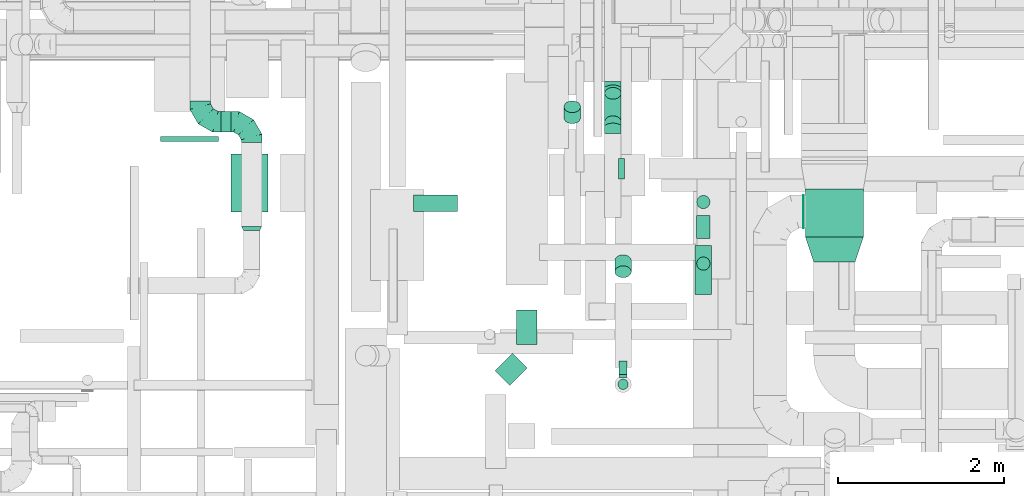
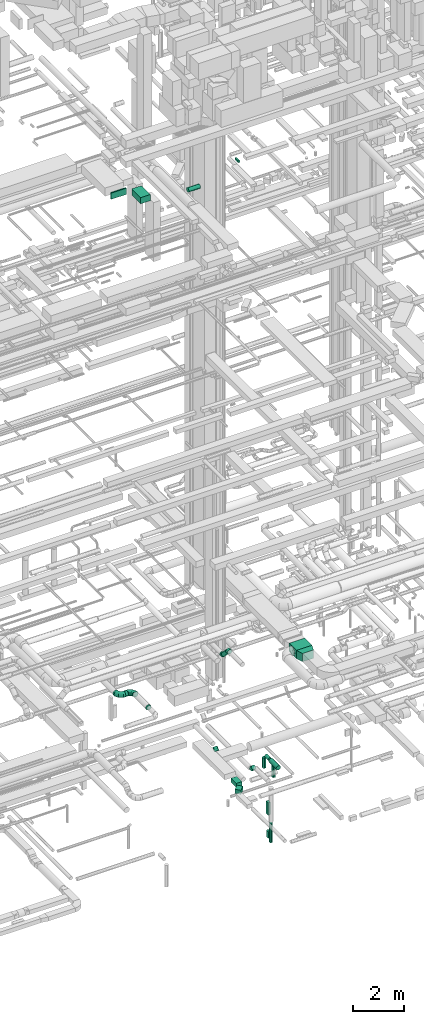
# One storey, part 160 of 337: 19 flow segments, 6 flow fittings.
"""IFC2X3 building model written with IfcOpenShell, lengths in millimetres."""

from ifc_helpers import new_model, entity, si_unit, converted_unit, derived_unit, direction, frame, origin, origin_2d_with_axis, place, context, subcontext, project, spatial, polyline, rectangle, circle, outline, extrude, faceted_brep, source, transform, mapped, material, type_object, type_shapes, element, save


model = new_model("IFC2X3")

# Units and contexts
model_context = context("Model", 3, precision=0.01, world=origin(), true_north=direction((6.12303176911189e-17, 1.0)))
body_context = subcontext(model_context, "Body", "Model", "MODEL_VIEW")
ifc_project = project(units=[si_unit("LENGTHUNIT", "METRE", prefix="MILLI"), si_unit("AREAUNIT", "SQUARE_METRE"), si_unit("VOLUMEUNIT", "CUBIC_METRE"), converted_unit("PLANEANGLEUNIT", "DEGREE", entity("IfcRatioMeasure", 0.0174532925199433), si_unit("PLANEANGLEUNIT", "RADIAN"), dimensions=[0, 0, 0, 0, 0, 0, 0]), si_unit("MASSUNIT", "GRAM", prefix="KILO"), derived_unit("MASSDENSITYUNIT", [(si_unit("MASSUNIT", "GRAM", prefix="KILO"), 1), (si_unit("LENGTHUNIT", "METRE"), -3)]), derived_unit("MOMENTOFINERTIAUNIT", [(si_unit("LENGTHUNIT", "METRE"), 4)]), si_unit("TIMEUNIT", "SECOND"), si_unit("FREQUENCYUNIT", "HERTZ"), si_unit("THERMODYNAMICTEMPERATUREUNIT", "DEGREE_CELSIUS"), derived_unit("THERMALTRANSMITTANCEUNIT", [(si_unit("MASSUNIT", "GRAM", prefix="KILO"), 1), (si_unit("THERMODYNAMICTEMPERATUREUNIT", "KELVIN"), -1), (si_unit("TIMEUNIT", "SECOND"), -3)]), derived_unit("VOLUMETRICFLOWRATEUNIT", [(si_unit("LENGTHUNIT", "METRE"), 3), (si_unit("TIMEUNIT", "SECOND"), -1)]), derived_unit("MASSFLOWRATEUNIT", [(si_unit("MASSUNIT", "GRAM", prefix="KILO"), 1), (si_unit("TIMEUNIT", "SECOND"), -1)]), derived_unit("ROTATIONALFREQUENCYUNIT", [(si_unit("TIMEUNIT", "SECOND"), -1)]), si_unit("ELECTRICCURRENTUNIT", "AMPERE"), si_unit("ELECTRICVOLTAGEUNIT", "VOLT"), si_unit("POWERUNIT", "WATT"), si_unit("FORCEUNIT", "NEWTON", prefix="KILO"), si_unit("ILLUMINANCEUNIT", "LUX"), si_unit("LUMINOUSFLUXUNIT", "LUMEN"), si_unit("LUMINOUSINTENSITYUNIT", "CANDELA"), derived_unit("USERDEFINED", [(si_unit("MASSUNIT", "GRAM", prefix="KILO"), -1), (si_unit("LENGTHUNIT", "METRE"), -2), (si_unit("TIMEUNIT", "SECOND"), 3), (si_unit("LUMINOUSFLUXUNIT", "LUMEN"), 1)]), derived_unit("LINEARVELOCITYUNIT", [(si_unit("LENGTHUNIT", "METRE"), 1), (si_unit("TIMEUNIT", "SECOND"), -1)]), si_unit("PRESSUREUNIT", "PASCAL"), derived_unit("USERDEFINED", [(si_unit("LENGTHUNIT", "METRE"), -2), (si_unit("MASSUNIT", "GRAM", prefix="KILO"), 1), (si_unit("TIMEUNIT", "SECOND"), -2)]), derived_unit("LINEARFORCEUNIT", [(si_unit("MASSUNIT", "GRAM", prefix="KILO"), 1), (si_unit("LENGTHUNIT", "METRE"), 1), (si_unit("TIMEUNIT", "SECOND"), -2), (si_unit("LENGTHUNIT", "METRE"), -1)]), derived_unit("PLANARFORCEUNIT", [(si_unit("MASSUNIT", "GRAM", prefix="KILO"), 1), (si_unit("LENGTHUNIT", "METRE"), 1), (si_unit("TIMEUNIT", "SECOND"), -2), (si_unit("LENGTHUNIT", "METRE"), -2)])], contexts=[model_context])

# Site, building, storey
site_placement = place(None, origin())
site = spatial("IfcSite", under=ifc_project, at=site_placement, CompositionType="ELEMENT")
building_placement = place(site_placement, origin())
building = spatial("IfcBuilding", under=site, at=building_placement, CompositionType="ELEMENT")
storey_placement = place(building_placement, origin())
storey = spatial("IfcBuildingStorey", under=building, at=storey_placement, CompositionType="ELEMENT", Elevation=0.0)

# Flow segments
duct_segment_type_1 = type_object("IfcDuctSegmentType", PredefinedType="NOTDEFINED")
flow_segment_1_placement = place(storey_placement, frame((42337.6, 4678.0, -950.0)))
element("IfcFlowSegment", 1, at=flow_segment_1_placement, inside=storey, type_object=duct_segment_type_1, context=body_context, shape_type="SweptSolid", body=[
    extrude(rectangle(XDim=419.303340347411, YDim=250.000000000004, at=origin_2d_with_axis()), frame((125.0, 209.65, 0.0), z_axis=(0.0, 0.0, 1.0), x_axis=(0.0, 1.0, 0.0)), (0.0, 0.0, 1.0), 200.0),
])
flow_segment_2_placement = place(storey_placement, frame((42081.75, 4183.25, -950.0)))
element("IfcFlowSegment", 2, at=flow_segment_2_placement, inside=storey, type_object=duct_segment_type_1, context=body_context, shape_type="SweptSolid", body=[
    extrude(rectangle(XDim=299.684199460135, YDim=249.999999999997, at=origin_2d_with_axis()), frame((194.34, 194.34, 0.0), z_axis=(0.0, 0.0, 1.0), x_axis=(0.707106781186551, 0.707106781186544, 0.0)), (0.0, 0.0, 1.0), 200.0),
])
flow_segment_3_placement = place(storey_placement, frame((43575.66, 4318.32, -2500.0)))
element("IfcFlowSegment", 3, at=flow_segment_3_placement, inside=storey, type_object=duct_segment_type_1, context=body_context, shape_type="SweptSolid", body=[
    extrude(rectangle(XDim=159.99999999999, YDim=100.000000000004, at=origin_2d_with_axis()), frame((50.0, 80.0, 0.0), z_axis=(0.0, 0.0, 1.0), x_axis=(-9.81578986625269e-06, 1.0, 0.0)), (0.0, 0.0, 1.0), 600.0),
])
flow_segment_4_placement = place(storey_placement, frame((43575.66, 4280.82, -3600.0)))
element("IfcFlowSegment", 4, at=flow_segment_4_placement, inside=storey, type_object=duct_segment_type_1, context=body_context, shape_type="SweptSolid", body=[
    extrude(rectangle(XDim=189.999999999926, YDim=100.000000000003, at=origin_2d_with_axis()), frame((50.0, 95.0, 0.0), z_axis=(0.0, 0.0, 1.0), x_axis=(0.0, 1.0, 0.0)), (0.0, 0.0, 1.0), 300.0),
])
flow_segment_5_placement = place(storey_placement, frame((43570.82, 6674.99, 27500.0)))
element("IfcFlowSegment", 5, at=flow_segment_5_placement, inside=storey, type_object=duct_segment_type_1, context=body_context, shape_type="SweptSolid", body=[
    extrude(rectangle(XDim=69.9999999999581, YDim=249.999999999999, at=origin_2d_with_axis()), frame((35.0, 125.0, 0.0), z_axis=(0.0, 0.0, 1.0), x_axis=(-1.0, 0.0, 0.0)), (0.0, 0.0, 1.0), 100.000000000003),
])
flow_segment_6_placement = place(storey_placement, frame((38045.62, 7127.81, 27400.0)))
element("IfcFlowSegment", 6, at=flow_segment_6_placement, inside=storey, type_object=duct_segment_type_1, context=body_context, shape_type="SweptSolid", body=[
    extrude(rectangle(XDim=60.0000000000643, YDim=700.000000000001, at=origin_2d_with_axis()), frame((350.0, 30.0, 0.0), z_axis=(0.0, 0.0, 1.0), x_axis=(0.0, 1.0, 0.0)), (0.0, 0.0, 1.0), 300.000000000001),
])
flow_segment_7_placement = place(storey_placement, frame((38895.62, 6277.81, 27400.0)))
element("IfcFlowSegment", 7, at=flow_segment_7_placement, inside=storey, type_object=duct_segment_type_1, context=body_context, shape_type="SweptSolid", body=[
    extrude(rectangle(XDim=445.00000000005, YDim=700.0, at=origin_2d_with_axis()), frame((222.5, 350.0, 0.0)), (0.0, 0.0, 1.0), 300.000000000001),
])
flow_segment_8_placement = place(storey_placement, frame((45825.84, 5976.24, 3250.0)))
element("IfcFlowSegment", 8, at=flow_segment_8_placement, inside=storey, type_object=duct_segment_type_1, context=body_context, shape_type="SweptSolid", body=[
    extrude(rectangle(XDim=580.0, YDim=699.999999999997, at=origin_2d_with_axis()), frame((350.0, 290.0, 0.0), z_axis=(0.0, 0.0, 1.0), x_axis=(0.0, -1.0, 0.0)), (0.0, 0.0, 1.0), 400.0),
])
duct_segment_type_2 = type_object("IfcDuctSegmentType", PredefinedType="NOTDEFINED")
flow_segment_9_placement = place(storey_placement, frame((43561.57, 4134.22, -3725.5)))
element("IfcFlowSegment", 9, at=flow_segment_9_placement, inside=storey, type_object=duct_segment_type_2, context=body_context, shape_type="SweptSolid", body=[
    extrude(circle(Radius=62.5, at=origin_2d_with_axis()), frame((64.1, 64.1, 0.0), z_axis=(0.0, 0.0, 1.0), x_axis=(0.0, 1.0, 0.0)), (0.0, 0.0, 1.0), 918.0),
])
flow_segment_10_placement = place(storey_placement, frame((44492.45, 5278.77, -1251.6)))
element("IfcFlowSegment", 10, at=flow_segment_10_placement, inside=storey, type_object=duct_segment_type_2, context=body_context, shape_type="SweptSolid", body=[
    extrude(circle(Radius=100.0, at=origin_2d_with_axis()), frame((101.6, 0.0, 101.6), z_axis=(0.0, 1.0, 0.0), x_axis=(1.0, 0.0, 0.0)), (0.0, 0.0, 1.0), 593.316198500005),
])
flow_segment_11_placement = place(storey_placement, frame((44512.45, 5957.09, -1231.6)))
element("IfcFlowSegment", 11, at=flow_segment_11_placement, inside=storey, type_object=duct_segment_type_2, context=body_context, shape_type="SweptSolid", body=[
    extrude(circle(Radius=80.0, at=origin_2d_with_axis()), frame((81.6, 0.0, 81.6), z_axis=(0.0, 1.0, 0.0), x_axis=(1.0, 0.0, 0.0)), (0.0, 0.0, 1.0), 280.1637215),
])
flow_segment_12_placement = place(storey_placement, frame((44512.45, 6315.65, -1800.0)))
element("IfcFlowSegment", 12, at=flow_segment_12_placement, inside=storey, type_object=duct_segment_type_2, context=body_context, shape_type="SweptSolid", body=[
    extrude(circle(Radius=80.0, at=origin_2d_with_axis()), frame((81.6, 81.6, 0.0), z_axis=(0.0, 0.0, 1.0), x_axis=(-1.0, 0.0, 0.0)), (0.0, 0.0, 1.0), 490.000000000003),
])
flow_segment_13_placement = place(storey_placement, frame((44512.45, 5572.69, -1800.0)))
element("IfcFlowSegment", 13, at=flow_segment_13_placement, inside=storey, type_object=duct_segment_type_2, context=body_context, shape_type="SweptSolid", body=[
    extrude(circle(Radius=80.0, at=origin_2d_with_axis()), frame((81.6, 81.6, 0.0), z_axis=(0.0, 0.0, 1.0), x_axis=(-1.0, 0.0, 0.0)), (0.0, 0.0, 1.0), 529.999999999992),
])
flow_segment_14_placement = place(storey_placement, frame((38774.14, 7238.45, 3053.4)))
element("IfcFlowSegment", 14, at=flow_segment_14_placement, inside=storey, type_object=duct_segment_type_2, context=body_context, shape_type="SweptSolid", body=[
    extrude(circle(Radius=125.0, at=origin_2d_with_axis()), frame((0.0, 126.6, 126.6), z_axis=(1.0, 0.0, 0.0), x_axis=(0.0, -1.0, 0.0)), (0.0, 0.0, 1.0), 120.000000000085),
])
flow_segment_15_placement = place(storey_placement, frame((45799.84, 6079.65, 3248.4)))
element("IfcFlowSegment", 15, at=flow_segment_15_placement, inside=storey, type_object=duct_segment_type_2, context=body_context, shape_type="SweptSolid", body=[
    extrude(circle(Radius=200.0, at=origin_2d_with_axis()), frame((0.0, 201.6, 201.6), z_axis=(1.0, 0.0, 0.0), x_axis=(0.0, 1.0, 0.0)), (0.0, 0.0, 1.0), 5.99962381503326),
])
flow_segment_16_placement = place(storey_placement, frame((43401.76, 7294.07, 3166.27)))
element("IfcFlowSegment", 16, at=flow_segment_16_placement, inside=storey, type_object=duct_segment_type_2, context=body_context, shape_type="SweptSolid", body=[
    extrude(circle(Radius=100.0, at=origin_2d_with_axis()), frame((101.6, 415.15, 72.31), z_axis=(0.0, -0.707106781186547, 0.707106781186548), x_axis=(1.0, 0.0, 0.0)), (0.0, 0.0, 1.0), 484.852813742394),
])
flow_segment_17_placement = place(storey_placement, frame((41099.04, 6279.91, 27138.4)))
element("IfcFlowSegment", 17, at=flow_segment_17_placement, inside=storey, type_object=duct_segment_type_2, context=body_context, shape_type="SweptSolid", body=[
    extrude(circle(Radius=100.0, at=origin_2d_with_axis()), frame((0.0, 101.6, 101.6), z_axis=(1.0, 0.0, 0.0), x_axis=(0.0, -1.0, 0.0)), (0.0, 0.0, 1.0), 530.000000000001),
])
flow_segment_18_placement = place(storey_placement, frame((43524.07, 5483.99, -1163.73)))
element("IfcFlowSegment", 18, at=flow_segment_18_placement, inside=storey, type_object=duct_segment_type_2, context=body_context, shape_type="SweptSolid", body=[
    extrude(circle(Radius=100.0, at=origin_2d_with_axis()), frame((101.6, 205.15, 72.31), z_axis=(0.0, -0.707106781186516, 0.707106781186579), x_axis=(1.0, 0.0, 0.0)), (0.0, 0.0, 1.0), 187.867965644044),
])
flow_segment_19_placement = place(storey_placement, frame((42911.05, 7342.0, -1163.73)))
element("IfcFlowSegment", 19, at=flow_segment_19_placement, inside=storey, type_object=duct_segment_type_2, context=body_context, shape_type="SweptSolid", body=[
    extrude(circle(Radius=100.0, at=origin_2d_with_axis()), frame((101.6, 72.31, 72.31), z_axis=(0.0, 0.707106781186487, 0.707106781186608), x_axis=(1.0, 0.0, 0.0)), (0.0, 0.0, 1.0), 187.8679853895),
])

# Flow fittings
ifc_material = material()
duct_fitting_type_1 = type_object("IfcDuctFittingType", PredefinedType="NOTDEFINED", material=ifc_material)
shared_shape_1 = source(origin(), body_context, "Body", "SweptSolid", [
    extrude(outline(polyline([(-63.25, -284.6), (252.98, -284.6), (31.62, 379.47), (-221.36, 189.74), (-63.25, -284.6)])), frame((150.0, 0.0, -200.0), z_axis=(0.0, 0.0, 1.0), x_axis=(0.948683298050513, -0.31622776601684, 0.0)), (0.0, 0.0, 1.0), 400.0),
])
type_shapes(duct_fitting_type_1, [shared_shape_1])
flow_fitting_1_placement = place(storey_placement, frame((46175.84, 5676.24, 3450.0), z_axis=(0.0, 0.0, 1.0), x_axis=(0.0, 1.0, 0.0)))
element("IfcFlowFitting", 20, at=flow_fitting_1_placement, inside=storey, type_object=duct_fitting_type_1, material=ifc_material, context=body_context, shape_type="MappedRepresentation", body=[
    mapped(shared_shape_1, transform((0.0, 0.0, 0.0), scale=1.0)),
])
duct_fitting_type_2 = type_object("IfcDuctFittingType", PredefinedType="NOTDEFINED", material=ifc_material)
shared_shape_2 = source(origin(), body_context, "Body", "Brep", [
    faceted_brep([(-250.0, 0.0, -125.0), (-250.0, -32.35, -120.74), (-250.0, -62.5, -108.25), (-250.0, -88.39, -88.39), (-250.0, -108.25, -62.5), (-250.0, -120.74, -32.35), (-250.0, -125.0, 0.0), (-250.0, -120.74, 32.35), (-250.0, -108.25, 62.5), (-250.0, -88.39, 88.39), (-250.0, -62.5, 108.25), (-250.0, -32.35, 120.74), (-250.0, 0.0, 125.0), (-250.0, 32.35, 120.74), (-250.0, 62.5, 108.25), (-250.0, 88.39, 88.39), (-250.0, 108.25, 62.5), (-250.0, 120.74, 32.35), (-250.0, 125.0, 0.0), (-250.0, 120.74, -32.35), (-250.0, 108.25, -62.5), (-250.0, 88.39, -88.39), (-250.0, 62.5, -108.25), (-250.0, 32.35, -120.74), (-191.68, 32.35, 120.74), (-199.76, 62.5, 108.25), (-183.01, 0.0, 125.0), (-206.7, 88.39, 88.39), (-215.37, 120.74, 32.35), (-216.51, 125.0, 0.0), (-212.02, 108.25, 62.5), (-212.02, 108.25, -62.5), (-206.7, 88.39, -88.39), (-215.37, 120.74, -32.35), (-191.68, 32.35, -120.74), (-183.01, 0.0, -125.0), (-199.76, 62.5, -108.25), (-174.34, -32.35, -120.74), (-166.27, -62.5, -108.25), (-159.33, -88.39, -88.39), (-154.01, -108.25, -62.5), (-150.66, -120.74, -32.35), (-149.52, -125.0, 0.0), (-150.66, -120.74, 32.35), (-154.01, -108.25, 62.5), (-159.33, -88.39, 88.39), (-166.27, -62.5, 108.25), (-174.34, -32.35, 120.74), (-90.67, 90.67, 120.74), (-112.74, 112.74, 108.25), (-66.99, 66.99, 125.0), (-131.69, 131.69, 88.39), (-146.23, 146.23, 62.5), (-155.38, 155.38, 32.35), (-158.49, 158.49, 0.0), (-155.38, 155.38, -32.35), (-146.23, 146.23, -62.5), (-131.69, 131.69, -88.39), (-90.67, 90.67, -120.74), (-66.99, 66.99, -125.0), (-112.74, 112.74, -108.25), (-43.3, 43.3, -120.74), (-21.23, 21.23, -108.25), (-2.28, 2.28, -88.39), (12.26, -12.26, -62.5), (21.4, -21.4, -32.35), (24.52, -24.52, 0.0), (21.4, -21.4, 32.35), (12.26, -12.26, 62.5), (-2.28, 2.28, 88.39), (-21.23, 21.23, 108.25), (-43.3, 43.3, 120.74), (-32.35, 191.68, 120.74), (-62.5, 199.76, 108.25), (0.0, 183.01, 125.0), (-88.39, 206.7, 88.39), (-108.25, 212.02, 62.5), (-120.74, 215.37, 32.35), (-125.0, 216.51, 0.0), (-120.74, 215.37, -32.35), (-108.25, 212.02, -62.5), (-88.39, 206.7, -88.39), (-32.35, 191.68, -120.74), (0.0, 183.01, -125.0), (-62.5, 199.76, -108.25), (32.35, 174.34, -120.74), (62.5, 166.27, -108.25), (88.39, 159.33, -88.39), (108.25, 154.01, -62.5), (120.74, 150.66, -32.35), (125.0, 149.52, 0.0), (120.74, 150.66, 32.35), (108.25, 154.01, 62.5), (88.39, 159.33, 88.39), (62.5, 166.27, 108.25), (32.35, 174.34, 120.74), (-32.35, 250.0, -120.74), (-62.5, 250.0, -108.25), (-88.39, 250.0, -88.39), (-108.25, 250.0, -62.5), (-120.74, 250.0, -32.35), (-125.0, 250.0, 0.0), (-120.74, 250.0, 32.35), (-108.25, 250.0, 62.5), (-88.39, 250.0, 88.39), (-62.5, 250.0, 108.25), (-32.35, 250.0, 120.74), (0.0, 250.0, 125.0), (32.35, 250.0, 120.74), (62.5, 250.0, 108.25), (88.39, 250.0, 88.39), (108.25, 250.0, 62.5), (120.74, 250.0, 32.35), (125.0, 250.0, 0.0), (120.74, 250.0, -32.35), (108.25, 250.0, -62.5), (88.39, 250.0, -88.39), (62.5, 250.0, -108.25), (32.35, 250.0, -120.74), (0.0, 250.0, -125.0)], [[[0, 1, 2, 3, 4, 5, 6, 7, 8, 9, 10, 11, 12, 13, 14, 15, 16, 17, 18, 19, 20, 21, 22, 23]], [[24, 25, 14, 13]], [[26, 24, 13, 12]], [[14, 25, 27, 15]], [[28, 29, 18, 17]], [[30, 28, 17, 16]], [[15, 27, 30, 16]], [[20, 31, 32, 21]], [[33, 31, 20, 19]], [[18, 29, 33, 19]], [[34, 35, 0, 23]], [[36, 34, 23, 22]], [[21, 32, 36, 22]], [[1, 0, 35, 37]], [[2, 1, 37, 38]], [[38, 39, 3, 2]], [[5, 4, 40, 41]], [[6, 5, 41, 42]], [[39, 40, 4, 3]], [[6, 42, 43, 7]], [[7, 43, 44, 8]], [[8, 44, 45, 9]], [[9, 45, 46, 10]], [[10, 46, 47, 11]], [[26, 12, 11, 47]], [[48, 49, 25, 24]], [[50, 48, 24, 26]], [[27, 25, 49, 51]], [[52, 53, 28, 30]], [[51, 52, 30, 27]], [[29, 28, 53, 54]], [[55, 56, 31, 33]], [[54, 55, 33, 29]], [[32, 31, 56, 57]], [[58, 59, 35, 34]], [[60, 58, 34, 36]], [[57, 60, 36, 32]], [[37, 35, 59, 61]], [[38, 37, 61, 62]], [[39, 38, 62, 63]], [[41, 40, 64, 65]], [[42, 41, 65, 66]], [[63, 64, 40, 39]], [[43, 42, 66, 67]], [[44, 43, 67, 68]], [[68, 69, 45, 44]], [[46, 45, 69, 70]], [[47, 46, 70, 71]], [[26, 47, 71, 50]], [[72, 73, 49, 48]], [[74, 72, 48, 50]], [[51, 49, 73, 75]], [[76, 77, 53, 52]], [[75, 76, 52, 51]], [[54, 53, 77, 78]], [[79, 80, 56, 55]], [[78, 79, 55, 54]], [[57, 56, 80, 81]], [[82, 83, 59, 58]], [[84, 82, 58, 60]], [[81, 84, 60, 57]], [[61, 59, 83, 85]], [[62, 61, 85, 86]], [[63, 62, 86, 87]], [[65, 64, 88, 89]], [[66, 65, 89, 90]], [[87, 88, 64, 63]], [[67, 66, 90, 91]], [[68, 67, 91, 92]], [[92, 93, 69, 68]], [[70, 69, 93, 94]], [[71, 70, 94, 95]], [[50, 71, 95, 74]], [[96, 97, 98, 99, 100, 101, 102, 103, 104, 105, 106, 107, 108, 109, 110, 111, 112, 113, 114, 115, 116, 117, 118, 119]], [[72, 74, 107, 106]], [[73, 72, 106, 105]], [[75, 73, 105, 104]], [[77, 76, 103, 102]], [[78, 77, 102, 101]], [[75, 104, 103, 76]], [[78, 101, 100, 79]], [[79, 100, 99, 80]], [[80, 99, 98, 81]], [[84, 97, 96, 82]], [[82, 96, 119, 83]], [[84, 81, 98, 97]], [[83, 119, 118, 85]], [[85, 118, 117, 86]], [[116, 87, 86, 117]], [[88, 115, 114, 89]], [[89, 114, 113, 90]], [[115, 88, 87, 116]], [[91, 90, 113, 112]], [[92, 91, 112, 111]], [[111, 110, 93, 92]], [[95, 94, 109, 108]], [[74, 95, 108, 107]], [[110, 109, 94, 93]]]),
])
type_shapes(duct_fitting_type_2, [shared_shape_2])
for number, where, z_axis, x_axis in (
    (21, (39144.14, 7365.04, 3180.0), (0.0, 0.0, 1.0), (0.0, 1.0, 0.0)),
    (22, (38524.14, 7365.04, 3180.0), (0.0, 0.0, 1.0), (0.0, -1.0, 0.0)),
):
    element("IfcFlowFitting", number, at=place(storey_placement, frame(where, z_axis=z_axis, x_axis=x_axis)), inside=storey, type_object=duct_fitting_type_2, material=ifc_material, context=body_context, shape_type="MappedRepresentation", body=[
        mapped(shared_shape_2, transform((0.0, 0.0, 0.0), scale=1.0)),
    ])
duct_fitting_type_3 = type_object("IfcDuctFittingType", PredefinedType="NOTDEFINED", material=ifc_material)
shared_shape_3 = source(origin(), body_context, "Body", "Brep", [
    faceted_brep([(-82.84, 0.0, -100.0), (-82.84, -25.88, -96.59), (-82.84, -50.0, -86.6), (-82.84, -70.71, -70.71), (-82.84, -86.6, -50.0), (-82.84, -96.59, -25.88), (-82.84, -100.0, 0.0), (-82.84, -96.59, 25.88), (-82.84, -86.6, 50.0), (-82.84, -70.71, 70.71), (-82.84, -50.0, 86.6), (-82.84, -25.88, 96.59), (-82.84, 0.0, 100.0), (-82.84, 25.88, 96.59), (-82.84, 50.0, 86.6), (-82.84, 70.71, 70.71), (-82.84, 86.6, 50.0), (-82.84, 96.59, 25.88), (-82.84, 100.0, 0.0), (-82.84, 96.59, -25.88), (-82.84, 86.6, -50.0), (-82.84, 70.71, -70.71), (-82.84, 50.0, -86.6), (-82.84, 25.88, -96.59), (-10.72, 25.88, 96.59), (-20.71, 50.0, 86.6), (0.0, 0.0, 100.0), (-29.29, 70.71, 70.71), (-35.87, 86.6, 50.0), (-40.01, 96.59, 25.88), (-41.42, 100.0, 0.0), (-40.01, 96.59, -25.88), (-35.87, 86.6, -50.0), (-29.29, 70.71, -70.71), (-10.72, 25.88, -96.59), (0.0, 0.0, -100.0), (-20.71, 50.0, -86.6), (10.72, -25.88, -96.59), (20.71, -50.0, -86.6), (29.29, -70.71, -70.71), (35.87, -86.6, -50.0), (40.01, -96.59, -25.88), (41.42, -100.0, 0.0), (40.01, -96.59, 25.88), (35.87, -86.6, 50.0), (29.29, -70.71, 70.71), (20.71, -50.0, 86.6), (10.72, -25.88, 96.59), (58.58, 58.58, 100.0), (40.28, 76.88, 96.59), (23.22, 93.93, 86.6), (8.58, 108.58, 70.71), (-2.66, 119.82, 50.0), (-9.72, 126.88, 25.88), (-12.13, 129.29, 0.0), (-9.72, 126.88, -25.88), (-2.66, 119.82, -50.0), (8.58, 108.58, -70.71), (23.22, 93.93, -86.6), (40.28, 76.88, -96.59), (58.58, 58.58, -100.0), (76.88, 40.28, -96.59), (93.93, 23.22, -86.6), (108.58, 8.58, -70.71), (119.82, -2.66, -50.0), (126.88, -9.72, -25.88), (129.29, -12.13, 0.0), (126.88, -9.72, 25.88), (119.82, -2.66, 50.0), (108.58, 8.58, 70.71), (93.93, 23.22, 86.6), (76.88, 40.28, 96.59)], [[[0, 1, 2, 3, 4, 5, 6, 7, 8, 9, 10, 11, 12, 13, 14, 15, 16, 17, 18, 19, 20, 21, 22, 23]], [[24, 25, 14, 13]], [[26, 24, 13, 12]], [[14, 25, 27, 15]], [[28, 29, 17, 16]], [[28, 16, 15, 27]], [[30, 18, 17, 29]], [[31, 32, 20, 19]], [[30, 31, 19, 18]], [[32, 33, 21, 20]], [[34, 35, 0, 23]], [[36, 34, 23, 22]], [[33, 36, 22, 21]], [[1, 0, 35, 37]], [[2, 1, 37, 38]], [[38, 39, 3, 2]], [[5, 4, 40, 41]], [[6, 5, 41, 42]], [[39, 40, 4, 3]], [[6, 42, 43, 7]], [[7, 43, 44, 8]], [[8, 44, 45, 9]], [[9, 45, 46, 10]], [[10, 46, 47, 11]], [[26, 12, 11, 47]], [[24, 26, 48, 49]], [[25, 24, 49, 50]], [[27, 25, 50, 51]], [[29, 28, 52, 53]], [[30, 29, 53, 54]], [[51, 52, 28, 27]], [[30, 54, 55, 31]], [[31, 55, 56, 32]], [[57, 33, 32, 56]], [[36, 58, 59, 34]], [[34, 59, 60, 35]], [[58, 36, 33, 57]], [[35, 60, 61, 37]], [[37, 61, 62, 38]], [[63, 39, 38, 62]], [[40, 64, 65, 41]], [[41, 65, 66, 42]], [[64, 40, 39, 63]], [[43, 42, 66, 67]], [[44, 43, 67, 68]], [[68, 69, 45, 44]], [[47, 46, 70, 71]], [[26, 47, 71, 48]], [[69, 70, 46, 45]], [[59, 58, 57, 56, 55, 54, 53, 52, 51, 50, 49, 48, 71, 70, 69, 68, 67, 66, 65, 64, 63, 62, 61, 60]]]),
])
type_shapes(duct_fitting_type_3, [shared_shape_3])
for number, where, z_axis, x_axis in (
    (23, (43503.36, 7307.79, 3640.0), (-1.0, 0.0, 0.0), (0.0, 1.0, 0.0)),
    (24, (43503.36, 7767.79, 3180.0), (1.0, 0.0, 0.0), (0.0, 0.707106781186515, -0.707106781186581)),
):
    element("IfcFlowFitting", number, at=place(storey_placement, frame(where, z_axis=z_axis, x_axis=x_axis)), inside=storey, type_object=duct_fitting_type_3, material=ifc_material, context=body_context, shape_type="MappedRepresentation", body=[
        mapped(shared_shape_3, transform((0.0, 0.0, 0.0), scale=1.0)),
    ])
duct_fitting_type_4 = type_object("IfcDuctFittingType", PredefinedType="NOTDEFINED", material=ifc_material)
shared_shape_4 = source(origin(), body_context, "Body", "Brep", [
    faceted_brep([(50.0, 80.9, -58.78), (50.0, 95.11, -30.9), (50.0, 100.0, 0.0), (50.0, 95.11, 30.9), (50.0, 80.9, 58.78), (50.0, 58.78, 80.9), (50.0, 30.9, 95.11), (50.0, 0.0, 100.0), (50.0, -30.9, 95.11), (50.0, -58.78, 80.9), (50.0, -80.9, 58.78), (50.0, -95.11, 30.9), (50.0, -100.0, 0.0), (50.0, -95.11, -30.9), (50.0, -80.9, -58.78), (50.0, -58.78, -80.9), (50.0, -30.9, -95.11), (50.0, 0.0, -100.0), (50.0, 30.9, -95.11), (50.0, 58.78, -80.9), (0.0, -125.0, 0.0), (0.0, -118.88, 38.63), (0.0, -101.13, 73.47), (0.0, -73.47, 101.13), (0.0, -38.63, 118.88), (0.0, 0.0, 125.0), (0.0, 38.63, 118.88), (0.0, 73.47, 101.13), (0.0, 101.13, 73.47), (0.0, 118.88, 38.63), (0.0, 125.0, 0.0), (0.0, 118.88, -38.63), (0.0, 101.13, -73.47), (0.0, 73.47, -101.13), (0.0, 38.63, -118.88), (0.0, 0.0, -125.0), (0.0, -38.63, -118.88), (0.0, -73.47, -101.13), (0.0, -101.13, -73.47), (0.0, -118.88, -38.63)], [[[0, 1, 2, 3, 4, 5, 6, 7, 8, 9, 10, 11, 12, 13, 14, 15, 16, 17, 18, 19]], [[20, 21, 22, 23, 24, 25, 26, 27, 28, 29, 30, 31, 32, 33, 34, 35, 36, 37, 38, 39]], [[26, 25, 7, 6]], [[27, 26, 6, 5]], [[5, 4, 28, 27]], [[3, 2, 30, 29]], [[4, 3, 29, 28]], [[21, 20, 12, 11]], [[22, 21, 11, 10]], [[10, 9, 23, 22]], [[8, 7, 25, 24]], [[9, 8, 24, 23]], [[36, 35, 17, 16]], [[37, 36, 16, 15]], [[15, 14, 38, 37]], [[13, 12, 20, 39]], [[14, 13, 39, 38]], [[31, 30, 2, 1]], [[32, 31, 1, 0]], [[0, 19, 33, 32]], [[18, 17, 35, 34]], [[19, 18, 34, 33]]]),
])
type_shapes(duct_fitting_type_4, [shared_shape_4])
flow_fitting_2_placement = place(storey_placement, frame((39144.14, 6105.04, 3178.39), z_axis=(0.0, 0.0, 1.0), x_axis=(0.0, -1.0, 0.0)))
element("IfcFlowFitting", 25, at=flow_fitting_2_placement, inside=storey, type_object=duct_fitting_type_4, material=ifc_material, context=body_context, shape_type="MappedRepresentation", body=[
    mapped(shared_shape_4, transform((0.0, 0.0, 0.0), scale=1.0)),
])

save(model, "model.ifc")
